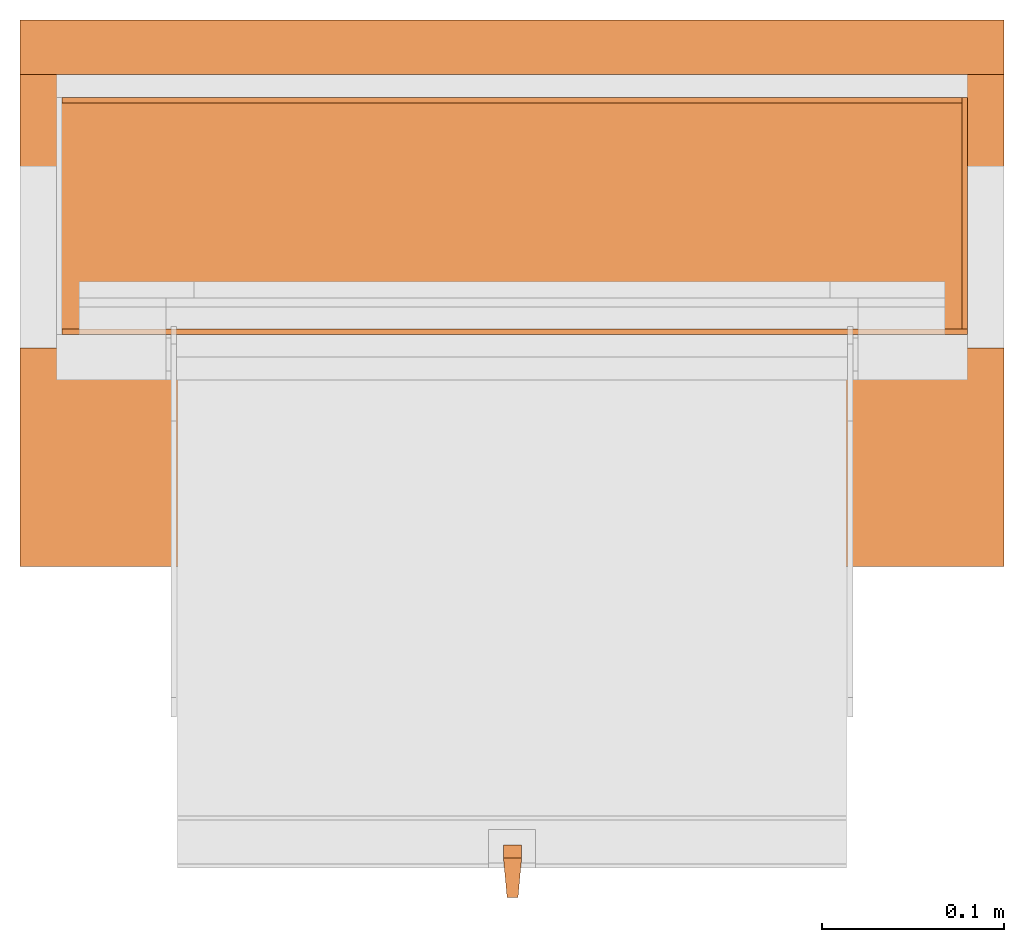
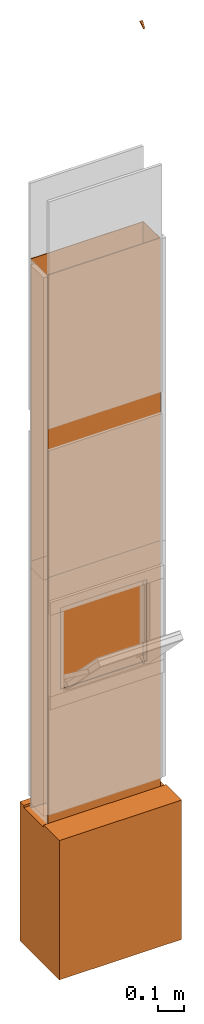
# One storey, part 3 of 3: 8 proxies, 1 opening.
"""IFC2X3 building model written with IfcOpenShell, lengths in metres."""

from ifc_helpers import new_model, entity, si_unit, converted_unit, derived_unit, money_unit, direction, frame, origin_with_axes, origin_2d_with_axis, place, context, subcontext, project, spatial, polyline, rectangle, outline, extrude, boolean, faceted_brep, source, transform, mapped, material, type_object, element, save


model = new_model("IFC2X3")

# Units and contexts
model_context = context("Model", 3, precision=1e-05, world=origin_with_axes(), true_north=direction((0.0, 1.0)))
plan_context = context("Plan", 3, precision=1e-05, world=origin_with_axes(), true_north=direction((0.0, 1.0)))
body_context = subcontext(model_context, "Body", "Model", "MODEL_VIEW")
ifc_project = project(units=[si_unit("LENGTHUNIT", "METRE"), si_unit("AREAUNIT", "SQUARE_METRE"), si_unit("VOLUMEUNIT", "CUBIC_METRE"), converted_unit("PLANEANGLEUNIT", "DEGREE", entity("IfcPlaneAngleMeasure", 0.0174532925199), si_unit("PLANEANGLEUNIT", "RADIAN"), dimensions=[0, 0, 0, 0, 0, 0, 0]), si_unit("SOLIDANGLEUNIT", "STERADIAN"), money_unit("CHF"), converted_unit("TIMEUNIT", "Year", entity("IfcTimeMeasure", 31556926.0), si_unit("TIMEUNIT", "SECOND"), dimensions=[0, 0, 1, 0, 0, 0, 0]), si_unit("MASSUNIT", "GRAM", prefix="KILO"), si_unit("THERMODYNAMICTEMPERATUREUNIT", "DEGREE_CELSIUS"), si_unit("LUMINOUSINTENSITYUNIT", "LUMEN"), si_unit("ENERGYUNIT", "JOULE", prefix="MEGA"), derived_unit("THERMALCONDUCTANCEUNIT", [(si_unit("POWERUNIT", "WATT"), 1), (si_unit("LENGTHUNIT", "METRE"), -1), (si_unit("THERMODYNAMICTEMPERATUREUNIT", "KELVIN"), -1)]), derived_unit("SPECIFICHEATCAPACITYUNIT", [(si_unit("ENERGYUNIT", "JOULE"), 1), (si_unit("MASSUNIT", "GRAM", prefix="KILO"), -1), (si_unit("THERMODYNAMICTEMPERATUREUNIT", "KELVIN"), -1)]), derived_unit("MASSDENSITYUNIT", [(si_unit("MASSUNIT", "GRAM", prefix="KILO"), 1), (si_unit("VOLUMEUNIT", "CUBIC_METRE"), -1)])], contexts=[model_context, plan_context])

# Site, building, storey
site_placement = place(None, origin_with_axes())
site = spatial("IfcSite", under=ifc_project, at=site_placement, CompositionType="ELEMENT")
building_placement = place(site_placement, origin_with_axes())
building = spatial("IfcBuilding", under=site, at=building_placement, CompositionType="ELEMENT")
storey_placement = place(building_placement, origin_with_axes())
storey = spatial("IfcBuildingStorey", under=building, at=storey_placement, Name="EG00", CompositionType="ELEMENT", Elevation=0.0)

# Proxies
ifc_material_1 = material(Name="Metall, Stahl")
building_element_proxy_type_1 = type_object("IfcBuildingElementProxyType", Name="Metall, Stahl 3", PredefinedType="NOTDEFINED")
proxy_1_placement = place(storey_placement, frame((9.61522436818, -3.75878861887, 0.0), z_axis=(0.0, 0.0, 1.0), x_axis=(-1.0, 0.0, 0.0)))
element("IfcBuildingElementProxy", 1, at=proxy_1_placement, inside=storey, type_object=building_element_proxy_type_1, material=ifc_material_1, Name="Wand-008", context=body_context, shape_type="CSG", body=[
    boolean("DIFFERENCE", boolean("DIFFERENCE", extrude(outline(polyline([(0.0, 0.0), (0.5, 0.0), (0.5, 0.003), (0.0, 0.003), (0.0, 0.0)])), origin_with_axes(), (0.0, 0.0, 1.0), 1.15), faceted_brep([(0.497, 0.003, 1.15), (0.497, 0.0, 1.15), (0.5, 0.0, 1.15), (0.5, 0.003, 1.15), (0.497, 0.0, 0.0), (0.497, 0.003, 0.0), (0.5, 0.0, 0.0), (0.5, 0.003, 0.0)], [[[0, 1, 2, 3]], [[4, 1, 0, 5]], [[1, 4, 6, 2]], [[2, 6, 7, 3]], [[5, 0, 3, 7]], [[4, 5, 7, 6]]])), faceted_brep([(0.003, 0.0, 0.0), (0.003, 0.0, 1.15), (0.0, 0.0, 1.15), (0.0, 0.0, 0.0), (0.003, 0.003, 1.15), (0.003, 0.003, 0.0), (0.0, 0.003, 1.15), (0.0, 0.003, 0.0)], [[[0, 1, 2, 3]], [[4, 1, 0, 5]], [[1, 4, 6, 2]], [[6, 7, 3, 2]], [[5, 0, 3, 7]], [[4, 5, 7, 6]]])),
])
proxy_2_placement = place(storey_placement, frame((9.61522436818, -3.88878861887, 0.0), z_axis=(0.0, 0.0, 1.0), x_axis=(0.0, 1.0, 0.0)))
element("IfcBuildingElementProxy", 2, at=proxy_2_placement, inside=storey, type_object=building_element_proxy_type_1, material=ifc_material_1, Name="Wand-007", context=body_context, shape_type="CSG", body=[
    boolean("DIFFERENCE", extrude(outline(polyline([(0.0, 0.0), (0.13, 0.0), (0.13, 0.003), (0.0, 0.003), (0.0, 0.0)])), origin_with_axes(), (0.0, 0.0, 1.0), 1.15), faceted_brep([(0.003, 0.0, 0.0), (0.003, 0.0, 1.15), (0.0, 0.0, 1.15), (0.0, 0.0, 0.0), (0.003, 0.003, 1.15), (0.003, 0.003, 0.0), (0.0, 0.003, 1.15), (0.0, 0.003, 0.0)], [[[0, 1, 2, 3]], [[4, 1, 0, 5]], [[1, 4, 6, 2]], [[6, 7, 3, 2]], [[5, 0, 3, 7]], [[4, 5, 7, 6]]])),
])

# Proxy, opening
proxy_3_placement = place(storey_placement, frame((9.11522436818, -3.88878861887, 0.0), z_axis=(0.0, 0.0, 1.0), x_axis=(1.0, 0.0, 0.0)))
proxy_3 = element("IfcBuildingElementProxy", 3, at=proxy_3_placement, inside=storey, type_object=building_element_proxy_type_1, material=ifc_material_1, Name="Wand-006", context=body_context, shape_type="CSG", body=[
    boolean("DIFFERENCE", extrude(outline(polyline([(0.0, 0.0), (0.5, 0.0), (0.5, 0.003), (0.0, 0.003), (0.0, 0.0)])), origin_with_axes(), (0.0, 0.0, 1.0), 1.15), faceted_brep([(0.003, 0.0, 1.15), (0.003, 0.003, 1.15), (0.0, 0.003, 1.15), (0.0, 0.0, 1.15), (0.003, 0.003, 0.0), (0.003, 0.0, 0.0), (0.0, 0.003, 0.0), (0.0, 0.0, 0.0)], [[[0, 1, 2, 3]], [[4, 1, 0, 5]], [[1, 4, 6, 2]], [[2, 6, 7, 3]], [[5, 0, 3, 7]], [[4, 5, 7, 6]]])),
])
opening_placement = place(proxy_3_placement, frame((-9.11522436818, 3.88878861887, 0.0), z_axis=(0.0, 0.0, 1.0), x_axis=(1.0, 0.0, 0.0)))
element("IfcOpeningElement", 4, at=opening_placement, cuts=proxy_3, Name="029", context=body_context, shape_type="SweptSolid", body=[
    extrude(rectangle(XDim=0.38, YDim=0.38, at=origin_2d_with_axis()), frame((9.36522436818, -3.91378861887, 0.8), z_axis=(0.0, -1.0, 0.0), x_axis=(1.0, 0.0, 0.0)), (0.0, 0.0, -1.0), 0.031),
])

# Proxies
proxy_4_placement = place(storey_placement, frame((9.61522436818, -3.75878861887, 1.15), z_axis=(0.0, 0.0, 1.0), x_axis=(-1.0, 0.0, 0.0)))
element("IfcBuildingElementProxy", 5, at=proxy_4_placement, inside=storey, type_object=building_element_proxy_type_1, material=ifc_material_1, Name="Wand-008", context=body_context, shape_type="CSG", body=[
    boolean("DIFFERENCE", boolean("DIFFERENCE", extrude(outline(polyline([(0.0, 0.0), (0.5, 0.0), (0.5, 0.003), (0.0, 0.003), (0.0, 0.0)])), origin_with_axes(), (0.0, 0.0, 1.0), 1.41), faceted_brep([(0.497, 0.003, 1.41), (0.497, 0.0, 1.41), (0.5, 0.0, 1.41), (0.5, 0.003, 1.41), (0.497, 0.0, 0.0), (0.497, 0.003, 0.0), (0.5, 0.0, 0.0), (0.5, 0.003, 0.0)], [[[0, 1, 2, 3]], [[4, 1, 0, 5]], [[1, 4, 6, 2]], [[2, 6, 7, 3]], [[5, 0, 3, 7]], [[4, 5, 7, 6]]])), faceted_brep([(0.003, 0.0, 0.0), (0.003, 0.0, 1.41), (0.0, 0.0, 1.41), (0.0, 0.0, 0.0), (0.003, 0.003, 1.41), (0.003, 0.003, 0.0), (0.0, 0.003, 1.41), (0.0, 0.003, 0.0)], [[[0, 1, 2, 3]], [[4, 1, 0, 5]], [[1, 4, 6, 2]], [[6, 7, 3, 2]], [[5, 0, 3, 7]], [[4, 5, 7, 6]]])),
])
proxy_5_placement = place(storey_placement, frame((9.61522436818, -3.88878861887, 1.15), z_axis=(0.0, 0.0, 1.0), x_axis=(0.0, 1.0, 0.0)))
element("IfcBuildingElementProxy", 6, at=proxy_5_placement, inside=storey, type_object=building_element_proxy_type_1, material=ifc_material_1, Name="Wand-007", context=body_context, shape_type="CSG", body=[
    boolean("DIFFERENCE", extrude(outline(polyline([(0.0, 0.0), (0.13, 0.0), (0.13, 0.003), (0.0, 0.003), (0.0, 0.0)])), origin_with_axes(), (0.0, 0.0, 1.0), 1.41), faceted_brep([(0.003, 0.0, 0.0), (0.003, 0.0, 1.41), (0.0, 0.0, 1.41), (0.0, 0.0, 0.0), (0.003, 0.003, 1.41), (0.003, 0.003, 0.0), (0.0, 0.003, 1.41), (0.0, 0.003, 0.0)], [[[0, 1, 2, 3]], [[4, 1, 0, 5]], [[1, 4, 6, 2]], [[6, 7, 3, 2]], [[5, 0, 3, 7]], [[4, 5, 7, 6]]])),
])
proxy_6_placement = place(storey_placement, frame((9.11522436818, -3.88878861887, 1.15), z_axis=(0.0, 0.0, 1.0), x_axis=(1.0, 0.0, 0.0)))
element("IfcBuildingElementProxy", 7, at=proxy_6_placement, inside=storey, type_object=building_element_proxy_type_1, material=ifc_material_1, Name="Wand-006", context=body_context, shape_type="CSG", body=[
    boolean("DIFFERENCE", extrude(outline(polyline([(0.0, 0.0), (0.5, 0.0), (0.5, 0.003), (0.0, 0.003), (0.0, 0.0)])), origin_with_axes(), (0.0, 0.0, 1.0), 1.41), faceted_brep([(0.003, 0.0, 1.41), (0.003, 0.003, 1.41), (0.0, 0.003, 1.41), (0.0, 0.0, 1.41), (0.003, 0.003, 0.0), (0.003, 0.0, 0.0), (0.0, 0.003, 0.0), (0.0, 0.0, 0.0)], [[[0, 1, 2, 3]], [[4, 1, 0, 5]], [[1, 4, 6, 2]], [[2, 6, 7, 3]], [[5, 0, 3, 7]], [[4, 5, 7, 6]]])),
])
ifc_material_2 = material(Name="Metall, Aluminium")
building_element_proxy_type_2 = type_object("IfcBuildingElementProxyType", Name="Metall, Aluminium", PredefinedType="NOTDEFINED")
shared_shape = source(origin_with_axes(), body_context, "Body", "Brep", [
    faceted_brep([(16.3891379247, -3.43334637562, 1.097), (16.3891379247, -3.44334637562, 1.097), (16.3921379247, -3.43534637562, 1.13058255688), (16.3991379247, -3.43334637562, 1.097), (16.3991379247, -3.44334637562, 1.097), (16.3921379247, -3.44134637562, 1.13058255688), (16.3961379247, -3.43523159518, 1.13058255688), (16.3961379247, -3.4414517679, 1.13058255688)], [[[0, 1, 2]], [[1, 0, 3, 4]], [[1, 5, 2]], [[0, 2, 3]], [[4, 3, 6]], [[5, 1, 4]], [[2, 5, 7]], [[3, 2, 6]], [[6, 7, 4]], [[7, 5, 4]], [[2, 7, 6]]]),
])
proxy_7_placement = place(storey_placement, frame((12.8038684551, -14.8694200011, 16.3044423362), z_axis=(0.0, -0.713898265506, -0.700249431636), x_axis=(0.0, 0.700249431636, -0.713898265506)))
element("IfcBuildingElementProxy", 8, at=proxy_7_placement, inside=storey, type_object=building_element_proxy_type_2, material=ifc_material_2, Name="Wand-008", context=body_context, shape_type="MappedRepresentation", body=[
    mapped(shared_shape, transform((0.0, 0.0, 0.0))),
])
ifc_material_3 = material(Name="Luft, horizontal")
building_element_proxy_type_3 = type_object("IfcBuildingElementProxyType", Name="Luft, horizontal 650", PredefinedType="NOTDEFINED")
proxy_8_placement = place(storey_placement, frame((9.09522436818, -4.01628861887, 0.01), z_axis=(0.0, 0.0, 1.0), x_axis=(1.0, 0.0, 0.0)))
element("IfcBuildingElementProxy", 9, at=proxy_8_placement, inside=storey, type_object=building_element_proxy_type_3, material=ifc_material_3, Name="Decke-007", context=body_context, shape_type="CSG", body=[
    boolean("DIFFERENCE", extrude(outline(polyline([(0.0, 0.0), (0.54, 0.0), (0.54, 0.3), (0.0, 0.3), (0.0, 0.0)])), frame((0.0, 0.0, -0.649830658354), z_axis=(0.0, 0.0, 1.0), x_axis=(1.0, 0.0, 0.0)), (0.0, 0.0, 1.0), 0.649830658354), faceted_brep([(0.54, 0.12, -0.01), (0.54, 0.27, -0.01), (0.54, 0.27, 0.0), (0.54, 0.12, 0.0), (0.0, 0.12, -0.01), (0.0, 0.27, -0.01), (0.0, 0.27, 0.0), (0.0, 0.12, 0.0)], [[[0, 1, 2, 3]], [[1, 0, 4, 5]], [[6, 2, 1, 5]], [[7, 3, 2, 6]], [[0, 3, 7, 4]], [[4, 7, 6, 5]]])),
])

save(model, "model.ifc")
